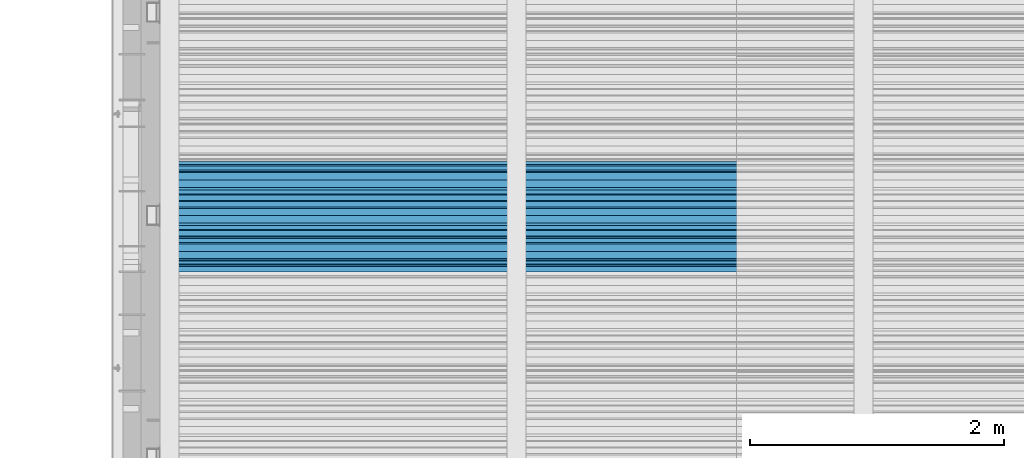
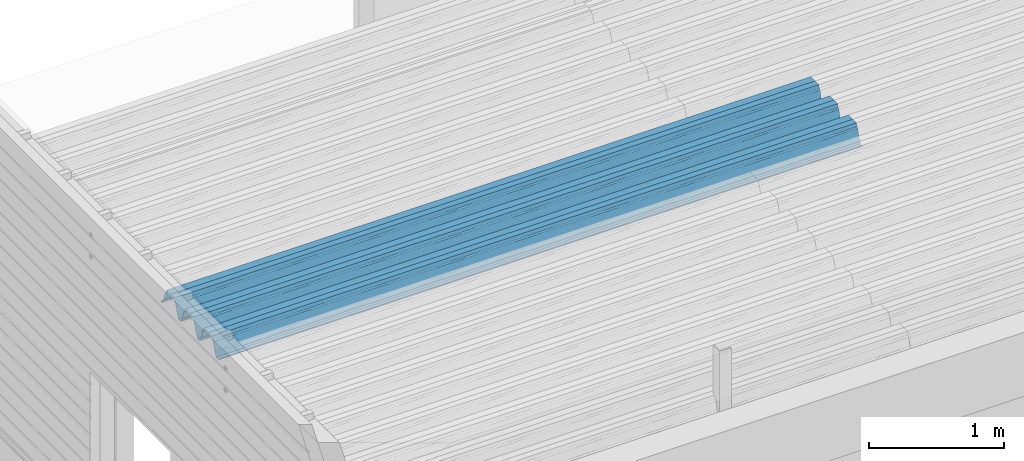
# One storey, part 26 of 153: 1 beam, 1 element without a shape of its own.
"""IFC2X3 building model written with IfcOpenShell, lengths in millimetres."""

import ifcopenshell
import ifcopenshell.guid

model = None  # the IFC model being written
_history = None  # IfcOwnerHistory: only IFC2X3 demands one
_inside = {}  # id of a spatial element -> (the spatial element, [elements in it])
_under = {}  # id of a project, library or spatial element -> (it, [spatial elements below it])
_declared = {}  # id of a project -> (the project, [libraries it declares])
_typed = {}  # id of a type object -> (the type object, [elements of that type])
_made_of = {}  # id of a material, layer set ... -> (it, [elements and type objects made of it])


def new_model(schema):
    """Start an empty IFC model of exactly this schema.

    Asked for "IFC4X3", IfcOpenShell would pick the latest addendum, in which some entities
    have other attributes; the version numbers below select the first issue.
    IFC2X3 requires an IfcOwnerHistory on every rooted entity: one is made here for all.
    """
    global model, _history
    if schema == "IFC4X3":
        model = ifcopenshell.file(schema_version=(4, 3, 0, 0))
    else:
        model = ifcopenshell.file(schema=schema)
    _inside.clear()
    _under.clear()
    _declared.clear()
    _typed.clear()
    _made_of.clear()
    _history = None
    if model.schema == "IFC2X3":
        org = make("IfcOrganization", Name="unknown")
        user = make(
            "IfcPersonAndOrganization",
            ThePerson=make("IfcPerson", FamilyName="unknown"),
            TheOrganization=org,
        )
        app = make(
            "IfcApplication",
            ApplicationDeveloper=org,
            Version="unknown",
            ApplicationFullName="unknown",
            ApplicationIdentifier="unknown",
        )
        _history = make(
            "IfcOwnerHistory",
            OwningUser=user,
            OwningApplication=app,
            ChangeAction="ADDED",
            CreationDate=0,
        )
    return model


def make(cls, **values):
    """One entity of the class cls with the attributes given. An attribute that is None is left unset."""
    return model.create_entity(
        cls, **{name: value for name, value in values.items() if value is not None}
    )


def rooted(cls, **values):
    """An entity with a GlobalId (a new one), such as an element, a storey or a relation."""
    return make(cls, GlobalId=ifcopenshell.guid.new(), OwnerHistory=_history, **values)


def si_unit(unit_type, name, prefix=None):
    """IfcSIUnit, for example si_unit("LENGTHUNIT", "METRE", prefix="MILLI")."""
    return make("IfcSIUnit", UnitType=unit_type, Prefix=prefix, Name=name)


def assignment(units):
    """IfcUnitAssignment: the units of a project."""
    return None if units is None else make("IfcUnitAssignment", Units=units)


def point(xyz):
    """IfcCartesianPoint."""
    return None if xyz is None else make("IfcCartesianPoint", Coordinates=xyz)


def direction(xyz):
    """IfcDirection."""
    return None if xyz is None else make("IfcDirection", DirectionRatios=xyz)


def frame(location, z_axis=None, x_axis=None):
    """IfcAxis2Placement3D, a coordinate frame: its origin and axes. An axis left out is left unset."""
    return make(
        "IfcAxis2Placement3D",
        Location=point(location),
        Axis=direction(z_axis),
        RefDirection=direction(x_axis),
    )


def origin_with_axes():
    """The frame at (0, 0, 0) with the z axis (0, 0, 1) and the x axis (1, 0, 0) written out."""
    return frame((0.0, 0.0, 0.0), z_axis=(0.0, 0.0, 1.0), x_axis=(1.0, 0.0, 0.0))


def place(relative_to, where):
    """IfcLocalPlacement: puts the frame where relative to a parent placement (None: the world)."""
    return make(
        "IfcLocalPlacement", PlacementRelTo=relative_to, RelativePlacement=where
    )


def context(
    kind, dimensions, precision=None, world=None, true_north=None, identifier=None
):
    """IfcGeometricRepresentationContext, for example the 3D "Model" context."""
    return make(
        "IfcGeometricRepresentationContext",
        ContextIdentifier=identifier,
        ContextType=kind,
        CoordinateSpaceDimension=dimensions,
        Precision=precision,
        WorldCoordinateSystem=world,
        TrueNorth=true_north,
    )


def subcontext(parent, identifier, kind, view, scale=None):
    """IfcGeometricRepresentationSubContext, for example "Body" below "Model"."""
    return make(
        "IfcGeometricRepresentationSubContext",
        ContextIdentifier=identifier,
        ContextType=kind,
        ParentContext=parent,
        TargetScale=scale,
        TargetView=view,
    )


def project(units=None, contexts=None):
    """IfcProject with its units and contexts."""
    return rooted(
        "IfcProject",
        Name="project",
        RepresentationContexts=contexts,
        UnitsInContext=assignment(units),
    )


def spatial(cls, under=None, at=None, **own):
    """A site, building, storey or space (cls), placed at a placement, below another one or the project."""
    s = rooted(cls, ObjectPlacement=at, **own)
    if under is not None:
        _under.setdefault(under.id(), (under, []))[1].append(s)
    return s


def faces_of(points, faces, orient=None, outer=None):
    """IfcFace entities. A face is a list of loops; a loop is a list of indices into points, from 0.

    orient and outer hold one flag for each loop. By default every Orientation is true, the
    first loop of a face is its IfcFaceOuterBound and the others are IfcFaceBound.
    """
    made = []
    for i, loops in enumerate(faces):
        bounds = []
        for j, loop in enumerate(loops):
            is_outer = j == 0 if outer is None else outer[i][j]
            bounds.append(
                make(
                    "IfcFaceOuterBound" if is_outer else "IfcFaceBound",
                    Bound=make("IfcPolyLoop", Polygon=[points[k] for k in loop]),
                    Orientation=True if orient is None else orient[i][j],
                )
            )
        made.append(make("IfcFace", Bounds=bounds))
    return made


def faceted_brep(points, faces, orient=None, outer=None, voids=None):
    """IfcFacetedBrep: a solid bounded by flat faces; with voids (closed shells), ...WithVoids."""
    shared = [point(p) for p in points]
    hull = make("IfcClosedShell", CfsFaces=faces_of(shared, faces, orient, outer))
    if voids is None:
        return make("IfcFacetedBrep", Outer=hull)
    return make(
        "IfcFacetedBrepWithVoids",
        Outer=hull,
        Voids=[
            make(cls, CfsFaces=faces_of(shared, fs, o, b)) for cls, fs, o, b in voids
        ],
    )


def shape(context_of_items, identifier, shape_type, items):
    """IfcShapeRepresentation: the items that make up one representation, for example the "Body"."""
    return make(
        "IfcShapeRepresentation",
        ContextOfItems=context_of_items,
        RepresentationIdentifier=identifier,
        RepresentationType=shape_type,
        Items=items,
    )


def material(Name=None, Category=None):
    """IfcMaterial."""
    return make("IfcMaterial", Name=Name, Category=Category)


def made_of(thing, what):
    """Note that an element or type object is made of a material, layer set ...; save() writes the relation."""
    if what is not None:
        _made_of.setdefault(what.id(), (what, []))[1].append(thing)
    return thing


def type_object(cls, material=None, **own):
    """A type object (cls), such as IfcWallType, which elements share."""
    return made_of(rooted(cls, **own), material)


def element(
    cls,
    number,
    at=None,
    inside=None,
    cuts=None,
    type_object=None,
    material=None,
    context=None,
    identifier="Body",
    shape_type=None,
    held_by="IfcProductDefinitionShape",
    body=None,
    shapes=None,
    **own,
):
    """One element of the class cls, such as IfcWall. Its Tag is "e" and its number.

    at: its placement. inside: the storey or other place that contains it. cuts: it is an
    opening in that element (IfcRelVoidsElement). A single representation is given by context,
    identifier, shape_type and body (its items); several are given by shapes. held_by: the class
    of the entity that holds the representations. save() writes the other relations.
    """
    e = rooted(cls, Tag="e%d" % number, ObjectPlacement=at, **own)
    if body is not None:
        shapes = [shape(context, identifier, shape_type, body)]
    if shapes is not None:
        e.Representation = make(held_by, Representations=shapes)
    if inside is not None:
        _inside.setdefault(inside.id(), (inside, []))[1].append(e)
    if cuts is not None:
        rooted(
            "IfcRelVoidsElement", RelatingBuildingElement=cuts, RelatedOpeningElement=e
        )
    if type_object is not None:
        _typed.setdefault(type_object.id(), (type_object, []))[1].append(e)
    return made_of(e, material)


def aggregate(whole, parts):
    """IfcRelAggregates: a whole, such as a stair, and the parts it consists of."""
    return rooted("IfcRelAggregates", RelatingObject=whole, RelatedObjects=parts)


def save(model, path):
    """Write the relations noted so far, then the file.

    IfcRelAggregates (storeys below a building ...), IfcRelContainedInSpatialStructure (elements
    in a storey), IfcRelDefinesByType, IfcRelAssociatesMaterial and IfcRelDeclares: one each for
    every whole, place, type object, material and project.
    """
    for whole, parts in _under.values():
        aggregate(whole, parts)
    for where, things in _inside.values():
        rooted(
            "IfcRelContainedInSpatialStructure",
            RelatedElements=things,
            RelatingStructure=where,
        )
    for kind, things in _typed.values():
        rooted("IfcRelDefinesByType", RelatedObjects=things, RelatingType=kind)
    for what, things in _made_of.values():
        rooted("IfcRelAssociatesMaterial", RelatedObjects=things, RelatingMaterial=what)
    for by, libraries in _declared.values():
        rooted("IfcRelDeclares", RelatingContext=by, RelatedDefinitions=libraries)
    model.write(path)


model = new_model("IFC2X3")

# Units and contexts
model_context = context("Model", 3, precision=1e-05, world=origin_with_axes())
body_context = subcontext(model_context, "Body", "Model", "MODEL_VIEW")
ifc_project = project(units=[si_unit("LENGTHUNIT", "METRE", prefix="MILLI"), si_unit("AREAUNIT", "SQUARE_METRE"), si_unit("VOLUMEUNIT", "CUBIC_METRE"), si_unit("MASSUNIT", "GRAM", prefix="KILO"), si_unit("TIMEUNIT", "SECOND"), si_unit("PLANEANGLEUNIT", "RADIAN"), si_unit("SOLIDANGLEUNIT", "STERADIAN"), si_unit("THERMODYNAMICTEMPERATUREUNIT", "DEGREE_CELSIUS"), si_unit("LUMINOUSINTENSITYUNIT", "LUMEN")], contexts=[model_context])

# Site, building, storey
site_placement = place(None, origin_with_axes())
site = spatial("IfcSite", under=ifc_project, at=site_placement, CompositionType="ELEMENT")
building_placement = place(site_placement, origin_with_axes())
building = spatial("IfcBuilding", under=site, at=building_placement, CompositionType="ELEMENT")
storey_placement = place(building_placement, origin_with_axes())
storey = spatial("IfcBuildingStorey", under=building, at=storey_placement, Name="8", CompositionType="ELEMENT", Elevation=0.0)

# Assembly, beam
assembly_placement = place(storey_placement, origin_with_axes())
assembly = element("IfcElementAssembly", 1, at=assembly_placement, inside=storey, Name="Steel Assembly", AssemblyPlace="NOTDEFINED", PredefinedType="RIGID_FRAME")
ifc_material = material(Name="STEEL/S355J2")
beam_type = type_object("IfcBeamType", Name="W", PredefinedType="NOTDEFINED")
beam_placement = place(assembly_placement, frame((13534.9999999929, 17875.0145456637, 105781.023065593), z_axis=(0.0, -0.0124990270013869, 0.999921884110963), x_axis=(-1.0, 3.00000001838171e-08, 0.0)))
beam = element("IfcBeam", 2, at=beam_placement, type_object=beam_type, material=ifc_material, ObjectType="W", context=body_context, shape_type="Brep", body=[
    faceted_brep([(0.0, -412.839996337891, -77.0100021362159), (0.0, -409.160003662109, -77.0100021362014), (5530.0, -409.160003662109, -77.0100021362014), (5530.0, -412.839996337891, -77.0100021362159), (0.0, -408.070007324222, -73.4800033569045), (5530.0, -408.070007324222, -73.4800033569045), (0.0, -400.339996337894, -48.0600013732619), (5530.0, -400.339996337894, -48.0600013732619), (0.0, -399.459991455082, -46.5600013732619), (5530.0, -399.459991455082, -46.5600013732619), (0.0, -390.329986572269, -36.5499992370314), (5530.0, -390.329986572269, -36.5499992370314), (0.0, -389.19000244141, -34.6300010680861), (5530.0, -389.19000244141, -34.6300010680861), (0.0, -367.820007324222, 35.3400001526024), (5530.0, -367.820007324222, 35.3400001526024), (0.0, -366.989990234379, 36.8499984741502), (5530.0, -366.989990234379, 36.8499984741502), (0.0, -357.809997558597, 46.8600006103807), (5530.0, -357.809997558597, 46.8600006103807), (0.0, -356.720001220707, 48.7700004577782), (5530.0, -356.720001220707, 48.7700004577782), (0.0, -349.309997558594, 73.1500015258935), (5530.0, -349.309997558594, 73.1500015258935), (0.0, -347.850006103516, 75.2300033569481), (5530.0, -347.850006103516, 75.2300033569481), (0.0, -345.470001220707, 76.010002136245), (5530.0, -345.470001220707, 76.010002136245), (0.0, -305.480010986332, 76.010002136245), (5530.0, -305.480010986332, 76.010002136245), (0.0, -304.279998779301, 75.8000030517578), (5530.0, -304.279998779301, 75.8000030517578), (0.0, -291.679992675785, 71.6999969482567), (5530.0, -291.679992675785, 71.6999969482567), (0.0, -290.179992675789, 71.2300033569481), (5530.0, -290.179992675789, 71.2300033569481), (0.0, -288.720001220707, 71.6999969482567), (5530.0, -288.720001220707, 71.6999969482567), (0.0, -276.119995117191, 75.8000030517869), (5530.0, -276.119995117191, 75.8000030517869), (0.0, -274.929992675785, 76.010002136245), (5530.0, -274.929992675785, 76.010002136245), (0.0, -234.94000244141, 76.010002136245), (5530.0, -234.94000244141, 76.010002136245), (0.0, -232.550003051758, 75.2300033569627), (5530.0, -232.550003051758, 75.2300033569627), (0.0, -231.100006103519, 73.1500015258935), (5530.0, -231.100006103519, 73.1500015258935), (0.0, -223.679992675785, 48.7700004577782), (5530.0, -223.679992675785, 48.7700004577782), (0.0, -222.589996337894, 46.8600006103661), (5530.0, -222.589996337894, 46.8600006103661), (0.0, -213.410003662113, 36.8499984741502), (5530.0, -213.410003662113, 36.8499984741502), (0.0, -212.529998779301, 35.3400001526024), (5530.0, -212.529998779301, 35.3400001526024), (0.0, -191.160003662109, -34.6300010681007), (5530.0, -191.160003662109, -34.6300010681007), (0.0, -190.070007324222, -36.5499992370605), (5530.0, -190.070007324222, -36.5499992370605), (0.0, -180.940002441406, -46.560001373291), (5530.0, -180.940002441406, -46.560001373291), (0.0, -180.059997558597, -48.0600013732619), (5530.0, -180.059997558597, -48.0600013732619), (0.0, -172.330001831055, -73.480003356919), (5530.0, -172.330001831055, -73.480003356919), (0.0, -171.240005493168, -77.0100021362159), (5530.0, -171.240005493168, -77.0100021362159), (0.0, -129.330001831062, -77.0100021362014), (5530.0, -129.330001831062, -77.0100021362014), (0.0, -128.300003051761, -73.480003356919), (5530.0, -128.300003051761, -73.480003356919), (0.0, -120.51999664307, -48.0600013732765), (5530.0, -120.51999664307, -48.0600013732765), (0.0, -119.629997253418, -46.5600013732765), (5530.0, -119.629997253418, -46.5600013732765), (0.0, -110.500000000004, -36.5499992370314), (5530.0, -110.500000000004, -36.5499992370314), (0.0, -109.419998168949, -34.6300010680861), (5530.0, -109.419998168949, -34.6300010680861), (0.0, -88.0500030517615, 35.3400001526024), (5530.0, -88.0500030517615, 35.3400001526024), (0.0, -87.160003662113, 36.8499984741356), (5530.0, -87.160003662113, 36.8499984741356), (0.0, -78.0400009155273, 46.8600006103807), (5530.0, -78.0400009155273, 46.8600006103807), (0.0, -76.8899993896557, 48.7700004577782), (5530.0, -76.8899993896557, 48.7700004577782), (0.0, -69.4800033569336, 73.1500015258935), (5530.0, -69.4800033569336, 73.1500015258935), (0.0, -68.0299987793042, 75.2300033569336), (5530.0, -68.0299987793042, 75.2300033569336), (0.0, -65.6399993896521, 76.010002136245), (5530.0, -65.6399993896521, 76.010002136245), (0.0, -25.6499996185375, 76.0100021362596), (5530.0, -25.6499996185375, 76.0100021362596), (0.0, -24.5100002288891, 75.8000030517724), (5530.0, -24.5100002288891, 75.8000030517724), (0.0, -11.8500003814697, 71.6999969482567), (5530.0, -11.8500003814697, 71.6999969482567), (0.0, -10.3999996185339, 71.2300033569481), (5530.0, -10.3999996185339, 71.2300033569481), (0.0, -8.89999961853391, 71.6999969482567), (5530.0, -8.89999961853391, 71.6999969482567), (0.0, 3.71000003814333, 75.8000030517724), (5530.0, 3.71000003814333, 75.8000030517724), (0.0, 4.90000009536379, 76.0100021362596), (5530.0, 4.90000009536379, 76.0100021362596), (0.0, 44.8899993896484, 76.010002136245), (5530.0, 44.8899993896484, 76.010002136245), (0.0, 47.2799987792932, 75.2300033569481), (5530.0, 47.2799987792932, 75.2300033569481), (0.0, 48.6800003051721, 73.1500015258935), (5530.0, 48.6800003051721, 73.1500015258935), (0.0, 56.1500015258753, 48.7700004577782), (5530.0, 56.1500015258753, 48.7700004577782), (0.0, 57.2400016784632, 46.8600006103807), (5530.0, 57.2400016784632, 46.8600006103807), (0.0, 66.3700027465784, 36.8499984741211), (5530.0, 66.3700027465784, 36.8499984741211), (0.0, 67.2499999999964, 35.3400001526024), (5530.0, 67.2499999999964, 35.3400001526024), (0.0, 88.6200027465748, -34.6300010681007), (5530.0, 88.6200027465748, -34.6300010681007), (0.0, 89.709999084469, -36.549999237046), (5530.0, 89.709999084469, -36.549999237046), (0.0, 98.8899993896412, -46.5600013732765), (5530.0, 98.8899993896412, -46.5600013732765), (0.0, 99.7699966430628, -48.0600013732765), (5530.0, 99.7699966430628, -48.0600013732765), (0.0, 107.499999999996, -73.4800033569336), (5530.0, 107.499999999996, -73.4800033569336), (0.0, 108.589996337887, -77.0100021362014), (5530.0, 108.589996337887, -77.0100021362014), (0.0, 112.269996643063, -77.0100021362159), (5530.0, 112.269996643063, -77.0100021362159), (0.0, 146.759994506836, -77.0100021362159), (5530.0, 146.759994506836, -77.0100021362159), (0.0, 150.440002441403, -77.0100021362159), (5530.0, 150.440002441403, -77.0100021362159), (0.0, 151.529998779297, -73.480003356919), (5530.0, 151.529998779297, -73.480003356919), (0.0, 159.30999755859, -48.0600013732765), (5530.0, 159.30999755859, -48.0600013732765), (0.0, 160.190002441406, -46.5600013732619), (5530.0, 160.190002441406, -46.5600013732619), (0.0, 169.320007324215, -36.549999237046), (5530.0, 169.320007324215, -36.549999237046), (0.0, 170.410003662106, -34.6300010680861), (5530.0, 170.410003662106, -34.6300010680861), (0.0, 191.779998779293, 35.3400001526024), (5530.0, 191.779998779293, 35.3400001526024), (0.0, 192.660003662109, 36.8499984741502), (5530.0, 192.660003662109, 36.8499984741502), (0.0, 201.789993286129, 46.8600006103661), (5530.0, 201.789993286129, 46.8600006103661), (0.0, 202.880004882809, 48.7700004577637), (5530.0, 202.880004882809, 48.7700004577637), (0.0, 210.350006103512, 73.150001525908), (5530.0, 210.350006103512, 73.150001525908), (0.0, 211.800003051754, 75.2300033569481), (5530.0, 211.800003051754, 75.2300033569481), (0.0, 214.190002441406, 76.010002136245), (5530.0, 214.190002441406, 76.010002136245), (0.0, 254.179992675778, 76.010002136245), (5530.0, 254.179992675778, 76.010002136245), (0.0, 255.320007324215, 75.8000030517869), (5530.0, 255.320007324215, 75.8000030517869), (0.0, 267.980010986324, 71.6999969482713), (5530.0, 267.980010986324, 71.6999969482713), (0.0, 269.429992675778, 71.2300033569481), (5530.0, 269.429992675778, 71.2300033569481), (0.0, 270.880004882809, 71.6999969482567), (5530.0, 270.880004882809, 71.6999969482567), (0.0, 283.540008544918, 75.8000030517869), (5530.0, 283.540008544918, 75.8000030517869), (0.0, 284.679992675778, 76.010002136245), (5530.0, 284.679992675778, 76.010002136245), (0.0, 324.670013427731, 76.010002136245), (5530.0, 324.670013427731, 76.010002136245), (0.0, 327.049987792969, 75.2300033569627), (5530.0, 327.049987792969, 75.2300033569627), (0.0, 328.510009765625, 73.1500015258789), (5530.0, 328.510009765625, 73.1500015258789), (0.0, 335.980010986324, 48.7700004577782), (5530.0, 335.980010986324, 48.7700004577782), (0.0, 337.05999755859, 46.8600006103661), (5530.0, 337.05999755859, 46.8600006103661), (0.0, 346.190002441399, 36.8499984741356), (5530.0, 346.190002441399, 36.8499984741356), (0.0, 347.079986572266, 35.3400001526024), (5530.0, 347.079986572266, 35.3400001526024), (0.0, 368.450012207028, -34.6300010680861), (5530.0, 368.450012207028, -34.6300010680861), (0.0, 369.529998779293, -36.5499992370314), (5530.0, 369.529998779293, -36.5499992370314), (0.0, 378.660003662106, -46.5600013732619), (5530.0, 378.660003662106, -46.5600013732619), (0.0, 379.540008544918, -48.0600013732619), (5530.0, 379.540008544918, -48.0600013732619), (0.0, 387.329986572262, -73.480003356919), (5530.0, 387.329986572262, -73.480003356919), (0.0, 388.410003662109, -77.0100021362159), (5530.0, 388.410003662109, -77.0100021362159), (0.0, 392.100006103512, -77.0100021362159), (5530.0, 392.100006103512, -77.0100021362159), (0.0, 426.589996337887, -77.0100021362159), (5530.0, 426.589996337887, -77.0100021362159), (0.0, 430.269989013668, -77.0100021362159), (5530.0, 430.269989013668, -77.0100021362159), (0.0, 431.359985351559, -73.4800033569045), (5530.0, 431.359985351559, -73.4800033569045), (0.0, 433.179992675778, -67.5699996948097), (5530.0, 433.179992675778, -67.5699996948097), (0.0, 432.220001220699, -67.2699966430373), (5530.0, 432.220001220699, -67.2699966430373), (0.0, 430.410003662106, -73.1800003051612), (5530.0, 430.410003662106, -73.1800003051612), (0.0, 429.529998779293, -76.0100021362159), (5530.0, 429.529998779293, -76.0100021362159), (0.0, 426.589996337891, -76.0100021362159), (5530.0, 426.589996337891, -76.0100021362159), (0.0, 392.100006103512, -76.0100021362159), (5530.0, 392.100006103512, -76.0100021362159), (0.0, 389.149993896481, -76.0100021362014), (5530.0, 389.149993896481, -76.0100021362014), (0.0, 388.279998779293, -73.1800003051467), (5530.0, 388.279998779293, -73.1800003051467), (0.0, 380.470001220699, -47.659999847383), (5530.0, 380.470001220699, -47.659999847383), (0.0, 379.470001220699, -45.9599990844436), (5530.0, 379.470001220699, -45.9599990844436), (0.0, 370.350006103512, -35.9599990844581), (5530.0, 370.350006103512, -35.9599990844581), (0.0, 369.369995117184, -34.2299995422218), (5530.0, 369.369995117184, -34.2299995422218), (0.0, 347.999999999996, 35.7500000000146), (5530.0, 347.999999999996, 35.7500000000146), (0.0, 346.999999999996, 37.4399986267235), (5530.0, 346.999999999996, 37.4399986267235), (0.0, 337.880004882809, 47.450000762954), (5530.0, 337.880004882809, 47.450000762954), (0.0, 336.899993896481, 49.1699981689453), (5530.0, 336.899993896481, 49.1699981689453), (0.0, 329.420013427731, 73.5999984741356), (5530.0, 329.420013427731, 73.5999984741356), (0.0, 327.679992675781, 76.0699996948533), (5530.0, 327.679992675781, 76.0699996948533), (0.0, 324.829986572262, 77.010002136245), (5530.0, 324.829986572262, 77.010002136245), (0.0, 284.589996337887, 77.010002136245), (5530.0, 284.589996337887, 77.010002136245), (0.0, 283.290008544922, 76.769996643081), (5530.0, 283.290008544922, 76.769996643081), (0.0, 270.570007324215, 72.6500015258935), (5530.0, 270.570007324215, 72.6500015258935), (0.0, 269.429992675781, 72.2799987793114), (5530.0, 269.429992675781, 72.2799987793114), (0.0, 268.279998779293, 72.650001525908), (5530.0, 268.279998779293, 72.650001525908), (0.0, 255.570007324219, 76.769996643081), (5530.0, 255.570007324219, 76.769996643081), (0.0, 254.270004272461, 77.0100021362596), (5530.0, 254.270004272461, 77.0100021362596), (0.0, 214.029998779293, 77.0100021362596), (5530.0, 214.029998779293, 77.0100021362596), (0.0, 211.179992675781, 76.0699996948388), (5530.0, 211.179992675781, 76.0699996948388), (0.0, 209.440002441403, 73.5999984741356), (5530.0, 209.440002441403, 73.5999984741356), (0.0, 201.960006713864, 49.1699981689599), (5530.0, 201.960006713864, 49.1699981689599), (0.0, 200.979995727532, 47.450000762954), (5530.0, 200.979995727532, 47.450000762954), (0.0, 191.850006103508, 37.4399986267235), (5530.0, 191.850006103508, 37.4399986267235), (0.0, 190.860000610352, 35.7500000000146), (5530.0, 190.860000610352, 35.7500000000146), (0.0, 169.49000549316, -34.2299995422218), (5530.0, 169.49000549316, -34.2299995422218), (0.0, 168.509994506832, -35.9599990844581), (5530.0, 168.509994506832, -35.9599990844581), (0.0, 159.380004882805, -45.9599990844436), (5530.0, 159.380004882805, -45.9599990844436), (0.0, 158.389999389645, -47.6599998473976), (5530.0, 158.389999389645, -47.6599998473976), (0.0, 150.580001831051, -73.1800003051612), (5530.0, 150.580001831051, -73.1800003051612), (0.0, 149.710006713864, -76.0100021362159), (5530.0, 149.710006713864, -76.0100021362159), (0.0, 146.759994506836, -76.0100021362159), (5530.0, 146.759994506836, -76.0100021362159), (0.0, 112.269996643063, -76.0100021362159), (5530.0, 112.269996643063, -76.0100021362159), (0.0, 109.319999694821, -76.0100021362159), (5530.0, 109.319999694821, -76.0100021362159), (0.0, 108.449996948239, -73.1900024413917), (5530.0, 108.449996948239, -73.1900024413917), (0.0, 100.690002441406, -47.659999847383), (5530.0, 100.690002441406, -47.659999847383), (0.0, 99.6999969482386, -45.9599990844581), (5530.0, 99.6999969482386, -45.9599990844581), (0.0, 90.5199966430664, -35.9599990844581), (5530.0, 90.5199966430664, -35.9599990844581), (0.0, 89.5400009155273, -34.2299995422218), (5530.0, 89.5400009155273, -34.2299995422218), (0.0, 68.1699981689417, 35.7500000000146), (5530.0, 68.1699981689417, 35.7500000000146), (0.0, 67.1699981689417, 37.4399986267235), (5530.0, 67.1699981689417, 37.4399986267235), (0.0, 58.0499992370569, 47.4500007629686), (5530.0, 58.0499992370569, 47.4500007629686), (0.0, 57.0699996948206, 49.1699981689599), (5530.0, 57.0699996948206, 49.1699981689599), (0.0, 49.5900001525843, 73.5899963379052), (5530.0, 49.5900001525843, 73.5899963379052), (0.0, 47.9099998474085, 76.0699996948388), (5530.0, 47.9099998474085, 76.0699996948388), (0.0, 45.0499992370569, 77.010002136245), (5530.0, 45.0499992370569, 77.010002136245), (0.0, 4.82000017165774, 77.010002136245), (5530.0, 4.82000017165774, 77.010002136245), (0.0, 3.47000002860659, 76.7699966430955), (5530.0, 3.47000002860659, 76.7699966430955), (0.0, -9.19999980926514, 72.6500015258935), (5530.0, -9.19999980926514, 72.6500015258935), (0.0, -10.3900003433264, 72.2799987792969), (5530.0, -10.3900003433264, 72.2799987792969), (0.0, -11.5399999618567, 72.6500015258935), (5530.0, -11.5399999618567, 72.6500015258935), (0.0, -24.2600002288855, 76.769996643081), (5530.0, -24.2600002288855, 76.769996643081), (0.0, -25.559999465946, 77.0100021362596), (5530.0, -25.559999465946, 77.0100021362596), (0.0, -65.8000030517615, 77.0100021362596), (5530.0, -65.8000030517615, 77.0100021362596), (0.0, -68.6500015258862, 76.0699996948533), (5530.0, -68.6500015258862, 76.0699996948533), (0.0, -70.3899993896521, 73.5999984741356), (5530.0, -70.3899993896521, 73.5999984741356), (0.0, -77.8199996948242, 49.1800003051903), (5530.0, -77.8199996948242, 49.1800003051903), (0.0, -78.8399963378943, 47.450000762954), (5530.0, -78.8399963378943, 47.450000762954), (0.0, -87.9700012207031, 37.4399986267235), (5530.0, -87.9700012207031, 37.4399986267235), (0.0, -88.9700012207068, 35.7500000000146), (5530.0, -88.9700012207068, 35.7500000000146), (0.0, -110.339996337894, -34.2299995422218), (5530.0, -110.339996337894, -34.2299995422218), (0.0, -111.319999694828, -35.9599990844581), (5530.0, -111.319999694828, -35.9599990844581), (0.0, -120.440002441406, -45.9599990844436), (5530.0, -120.440002441406, -45.9599990844436), (0.0, -121.44000244141, -47.6599998473976), (5530.0, -121.44000244141, -47.6599998473976), (0.0, -129.250000000004, -73.1900024413771), (5530.0, -129.250000000004, -73.1900024413771), (0.0, -130.080001831062, -76.0100021362159), (5530.0, -130.080001831062, -76.0100021362159), (0.0, -170.5, -76.0100021362014), (5530.0, -170.5, -76.0100021362014), (0.0, -171.380004882816, -73.1900024413917), (5530.0, -171.380004882816, -73.1900024413917), (0.0, -179.139999389652, -47.6599998473976), (5530.0, -179.139999389652, -47.6599998473976), (0.0, -180.130004882816, -45.9599990844581), (5530.0, -180.130004882816, -45.9599990844581), (0.0, -189.259994506836, -35.9599990844581), (5530.0, -189.259994506836, -35.9599990844581), (0.0, -190.240005493168, -34.2299995422218), (5530.0, -190.240005493168, -34.2299995422218), (0.0, -211.610000610355, 35.7500000000146), (5530.0, -211.610000610355, 35.7500000000146), (0.0, -212.600006103519, 37.4399986267381), (5530.0, -212.600006103519, 37.4399986267381), (0.0, -221.779998779301, 47.450000762954), (5530.0, -221.779998779301, 47.450000762954), (0.0, -222.75999450684, 49.1699981689599), (5530.0, -222.75999450684, 49.1699981689599), (0.0, -230.190002441406, 73.5999984741356), (5530.0, -230.190002441406, 73.5999984741356), (0.0, -231.919998168945, 76.0699996948388), (5530.0, -231.919998168945, 76.0699996948388), (0.0, -234.779998779301, 77.010002136245), (5530.0, -234.779998779301, 77.010002136245), (0.0, -275.010009765629, 77.010002136245), (5530.0, -275.010009765629, 77.010002136245), (0.0, -276.359985351563, 76.769996643081), (5530.0, -276.359985351563, 76.769996643081), (0.0, -289.029998779297, 72.6500015258789), (5530.0, -289.029998779297, 72.6500015258789), (0.0, -290.179992675785, 72.2799987793114), (5530.0, -290.179992675785, 72.2799987793114), (0.0, -291.380004882816, 72.650001525908), (5530.0, -291.380004882816, 72.650001525908), (0.0, -304.040008544926, 76.769996643081), (5530.0, -304.040008544926, 76.769996643081), (0.0, -305.390014648441, 77.010002136245), (5530.0, -305.390014648441, 77.010002136245), (0.0, -345.63000488282, 77.0100021362596), (5530.0, -345.63000488282, 77.0100021362596), (0.0, -348.480010986332, 76.0699996948388), (5530.0, -348.480010986332, 76.0699996948388), (0.0, -350.220001220707, 73.5999984741356), (5530.0, -350.220001220707, 73.5999984741356), (0.0, -357.649993896492, 49.1699981689599), (5530.0, -357.649993896492, 49.1699981689599), (0.0, -358.63000488282, 47.450000762954), (5530.0, -358.63000488282, 47.450000762954), (0.0, -367.809997558594, 37.4300003051903), (5530.0, -367.809997558594, 37.4300003051903), (0.0, -368.750000000004, 35.7299995422654), (5530.0, -368.750000000004, 35.7299995422654), (0.0, -390.109985351566, -34.2200012207031), (5530.0, -390.109985351566, -34.2200012207031), (0.0, -391.140014648441, -35.9500007629249), (5530.0, -391.140014648441, -35.9500007629249), (0.0, -400.269989013676, -45.9599990844436), (5530.0, -400.269989013676, -45.9599990844436), (0.0, -401.269989013672, -47.6599998473976), (5530.0, -401.269989013672, -47.6599998473976), (0.0, -409.029998779297, -73.1900024413917), (5530.0, -409.029998779297, -73.1900024413917), (0.0, -409.899993896488, -76.0100021362159), (5530.0, -409.899993896488, -76.0100021362159), (0.0, -412.839996337891, -76.0100021362159), (5530.0, -412.839996337891, -76.0100021362159), (0.0, -433.179992675785, -76.0100021362159), (5530.0, -433.179992675785, -76.0100021362159), (0.0, -433.179992675785, -77.0100021362159), (5530.0, -433.179992675785, -77.0100021362159)], [[[0, 1, 2, 3]], [[1, 4, 5, 2]], [[4, 6, 7, 5]], [[6, 8, 9, 7]], [[8, 10, 11, 9]], [[10, 12, 13, 11]], [[12, 14, 15, 13]], [[14, 16, 17, 15]], [[16, 18, 19, 17]], [[18, 20, 21, 19]], [[20, 22, 23, 21]], [[22, 24, 25, 23]], [[24, 26, 27, 25]], [[26, 28, 29, 27]], [[28, 30, 31, 29]], [[30, 32, 33, 31]], [[32, 34, 35, 33]], [[34, 36, 37, 35]], [[36, 38, 39, 37]], [[38, 40, 41, 39]], [[40, 42, 43, 41]], [[42, 44, 45, 43]], [[44, 46, 47, 45]], [[46, 48, 49, 47]], [[48, 50, 51, 49]], [[50, 52, 53, 51]], [[52, 54, 55, 53]], [[54, 56, 57, 55]], [[56, 58, 59, 57]], [[58, 60, 61, 59]], [[60, 62, 63, 61]], [[62, 64, 65, 63]], [[64, 66, 67, 65]], [[66, 68, 69, 67]], [[68, 70, 71, 69]], [[70, 72, 73, 71]], [[72, 74, 75, 73]], [[74, 76, 77, 75]], [[76, 78, 79, 77]], [[78, 80, 81, 79]], [[80, 82, 83, 81]], [[82, 84, 85, 83]], [[84, 86, 87, 85]], [[86, 88, 89, 87]], [[88, 90, 91, 89]], [[90, 92, 93, 91]], [[92, 94, 95, 93]], [[94, 96, 97, 95]], [[96, 98, 99, 97]], [[98, 100, 101, 99]], [[100, 102, 103, 101]], [[102, 104, 105, 103]], [[104, 106, 107, 105]], [[106, 108, 109, 107]], [[108, 110, 111, 109]], [[110, 112, 113, 111]], [[112, 114, 115, 113]], [[114, 116, 117, 115]], [[116, 118, 119, 117]], [[118, 120, 121, 119]], [[120, 122, 123, 121]], [[122, 124, 125, 123]], [[124, 126, 127, 125]], [[126, 128, 129, 127]], [[128, 130, 131, 129]], [[130, 132, 133, 131]], [[132, 134, 135, 133]], [[134, 136, 137, 135]], [[136, 138, 139, 137]], [[138, 140, 141, 139]], [[140, 142, 143, 141]], [[142, 144, 145, 143]], [[144, 146, 147, 145]], [[146, 148, 149, 147]], [[148, 150, 151, 149]], [[150, 152, 153, 151]], [[152, 154, 155, 153]], [[154, 156, 157, 155]], [[156, 158, 159, 157]], [[158, 160, 161, 159]], [[160, 162, 163, 161]], [[162, 164, 165, 163]], [[164, 166, 167, 165]], [[166, 168, 169, 167]], [[168, 170, 171, 169]], [[170, 172, 173, 171]], [[172, 174, 175, 173]], [[174, 176, 177, 175]], [[176, 178, 179, 177]], [[178, 180, 181, 179]], [[180, 182, 183, 181]], [[182, 184, 185, 183]], [[184, 186, 187, 185]], [[186, 188, 189, 187]], [[188, 190, 191, 189]], [[190, 192, 193, 191]], [[192, 194, 195, 193]], [[194, 196, 197, 195]], [[196, 198, 199, 197]], [[198, 200, 201, 199]], [[200, 202, 203, 201]], [[202, 204, 205, 203]], [[204, 206, 207, 205]], [[206, 208, 209, 207]], [[208, 210, 211, 209]], [[210, 212, 213, 211]], [[212, 214, 215, 213]], [[214, 216, 217, 215]], [[216, 218, 219, 217]], [[218, 220, 221, 219]], [[220, 222, 223, 221]], [[222, 224, 225, 223]], [[224, 226, 227, 225]], [[226, 228, 229, 227]], [[228, 230, 231, 229]], [[230, 232, 233, 231]], [[232, 234, 235, 233]], [[234, 236, 237, 235]], [[236, 238, 239, 237]], [[238, 240, 241, 239]], [[240, 242, 243, 241]], [[242, 244, 245, 243]], [[244, 246, 247, 245]], [[246, 248, 249, 247]], [[248, 250, 251, 249]], [[250, 252, 253, 251]], [[252, 254, 255, 253]], [[254, 256, 257, 255]], [[256, 258, 259, 257]], [[258, 260, 261, 259]], [[260, 262, 263, 261]], [[262, 264, 265, 263]], [[264, 266, 267, 265]], [[266, 268, 269, 267]], [[268, 270, 271, 269]], [[270, 272, 273, 271]], [[272, 274, 275, 273]], [[274, 276, 277, 275]], [[276, 278, 279, 277]], [[278, 280, 281, 279]], [[280, 282, 283, 281]], [[282, 284, 285, 283]], [[284, 286, 287, 285]], [[286, 288, 289, 287]], [[288, 290, 291, 289]], [[290, 292, 293, 291]], [[292, 294, 295, 293]], [[294, 296, 297, 295]], [[296, 298, 299, 297]], [[298, 300, 301, 299]], [[300, 302, 303, 301]], [[302, 304, 305, 303]], [[304, 306, 307, 305]], [[306, 308, 309, 307]], [[308, 310, 311, 309]], [[310, 312, 313, 311]], [[312, 314, 315, 313]], [[314, 316, 317, 315]], [[316, 318, 319, 317]], [[318, 320, 321, 319]], [[320, 322, 323, 321]], [[322, 324, 325, 323]], [[324, 326, 327, 325]], [[326, 328, 329, 327]], [[328, 330, 331, 329]], [[330, 332, 333, 331]], [[332, 334, 335, 333]], [[334, 336, 337, 335]], [[336, 338, 339, 337]], [[338, 340, 341, 339]], [[340, 342, 343, 341]], [[342, 344, 345, 343]], [[344, 346, 347, 345]], [[346, 348, 349, 347]], [[348, 350, 351, 349]], [[350, 352, 353, 351]], [[352, 354, 355, 353]], [[354, 356, 357, 355]], [[356, 358, 359, 357]], [[358, 360, 361, 359]], [[360, 362, 363, 361]], [[362, 364, 365, 363]], [[364, 366, 367, 365]], [[366, 368, 369, 367]], [[368, 370, 371, 369]], [[370, 372, 373, 371]], [[372, 374, 375, 373]], [[374, 376, 377, 375]], [[376, 378, 379, 377]], [[378, 380, 381, 379]], [[380, 382, 383, 381]], [[382, 384, 385, 383]], [[384, 386, 387, 385]], [[386, 388, 389, 387]], [[388, 390, 391, 389]], [[390, 392, 393, 391]], [[392, 394, 395, 393]], [[394, 396, 397, 395]], [[396, 398, 399, 397]], [[398, 400, 401, 399]], [[400, 402, 403, 401]], [[402, 404, 405, 403]], [[404, 406, 407, 405]], [[406, 408, 409, 407]], [[408, 410, 411, 409]], [[410, 412, 413, 411]], [[412, 414, 415, 413]], [[414, 416, 417, 415]], [[416, 418, 419, 417]], [[418, 420, 421, 419]], [[420, 422, 423, 421]], [[422, 424, 425, 423]], [[424, 426, 427, 425]], [[426, 428, 429, 427]], [[428, 430, 431, 429]], [[430, 0, 3, 431]], [[5, 7, 9, 11, 13, 15, 17, 19, 21, 23, 25, 27, 29, 31, 33, 35, 37, 39, 41, 43, 45, 47, 49, 51, 53, 55, 57, 59, 61, 63, 65, 67, 69, 71, 73, 75, 77, 79, 81, 83, 85, 87, 89, 91, 93, 95, 97, 99, 101, 103, 105, 107, 109, 111, 113, 115, 117, 119, 121, 123, 125, 127, 129, 131, 133, 135, 137, 139, 141, 143, 145, 147, 149, 151, 153, 155, 157, 159, 161, 163, 165, 167, 169, 171, 173, 175, 177, 179, 181, 183, 185, 187, 189, 191, 193, 195, 197, 199, 201, 203, 205, 207, 209, 211, 213, 215, 217, 219, 221, 223, 225, 227, 229, 231, 233, 235, 237, 239, 241, 243, 245, 247, 249, 251, 253, 255, 257, 259, 261, 263, 265, 267, 269, 271, 273, 275, 277, 279, 281, 283, 285, 287, 289, 291, 293, 295, 297, 299, 301, 303, 305, 307, 309, 311, 313, 315, 317, 319, 321, 323, 325, 327, 329, 331, 333, 335, 337, 339, 341, 343, 345, 347, 349, 351, 353, 355, 357, 359, 361, 363, 365, 367, 369, 371, 373, 375, 377, 379, 381, 383, 385, 387, 389, 391, 393, 395, 397, 399, 401, 403, 405, 407, 409, 411, 413, 415, 417, 419, 421, 423, 425, 427, 429, 431, 3, 2]], [[430, 428, 426, 424, 422, 420, 418, 416, 414, 412, 410, 408, 406, 404, 402, 400, 398, 396, 394, 392, 390, 388, 386, 384, 382, 380, 378, 376, 374, 372, 370, 368, 366, 364, 362, 360, 358, 356, 354, 352, 350, 348, 346, 344, 342, 340, 338, 336, 334, 332, 330, 328, 326, 324, 322, 320, 318, 316, 314, 312, 310, 308, 306, 304, 302, 300, 298, 296, 294, 292, 290, 288, 286, 284, 282, 280, 278, 276, 274, 272, 270, 268, 266, 264, 262, 260, 258, 256, 254, 252, 250, 248, 246, 244, 242, 240, 238, 236, 234, 232, 230, 228, 226, 224, 222, 220, 218, 216, 214, 212, 210, 208, 206, 204, 202, 200, 198, 196, 194, 192, 190, 188, 186, 184, 182, 180, 178, 176, 174, 172, 170, 168, 166, 164, 162, 160, 158, 156, 154, 152, 150, 148, 146, 144, 142, 140, 138, 136, 134, 132, 130, 128, 126, 124, 122, 120, 118, 116, 114, 112, 110, 108, 106, 104, 102, 100, 98, 96, 94, 92, 90, 88, 86, 84, 82, 80, 78, 76, 74, 72, 70, 68, 66, 64, 62, 60, 58, 56, 54, 52, 50, 48, 46, 44, 42, 40, 38, 36, 34, 32, 30, 28, 26, 24, 22, 20, 18, 16, 14, 12, 10, 8, 6, 4, 1, 0]]]),
])
aggregate(assembly, [beam])

save(model, "model.ifc")
